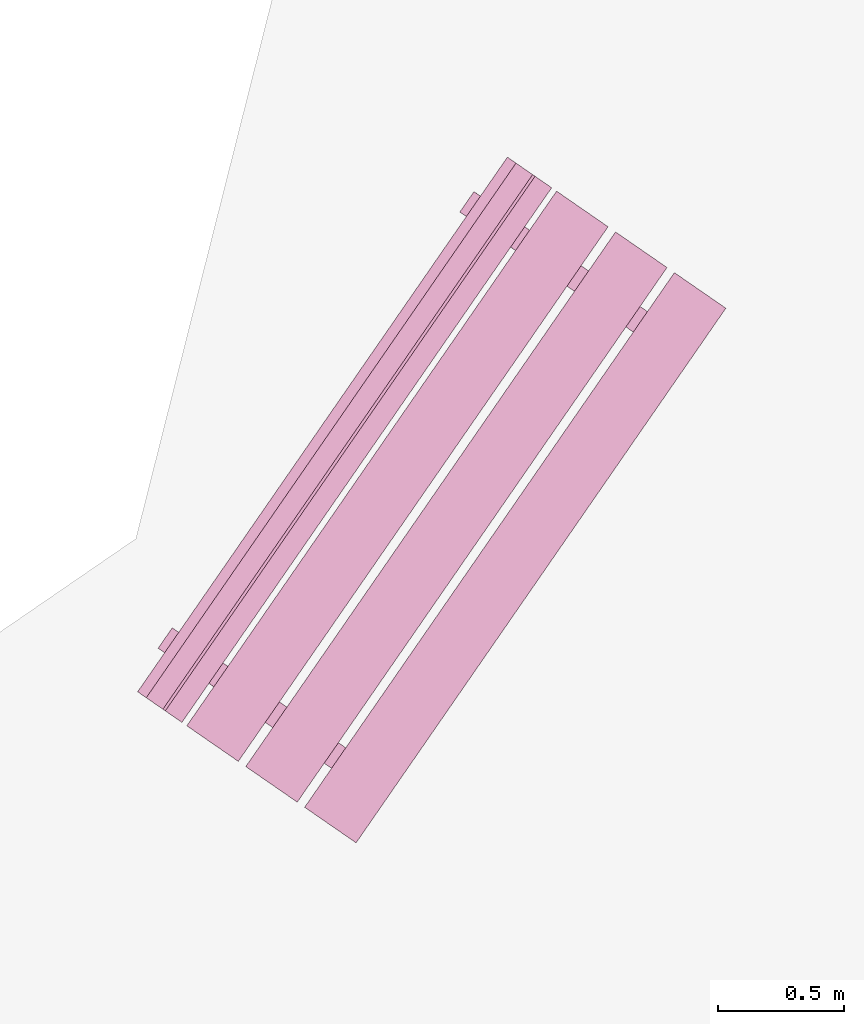
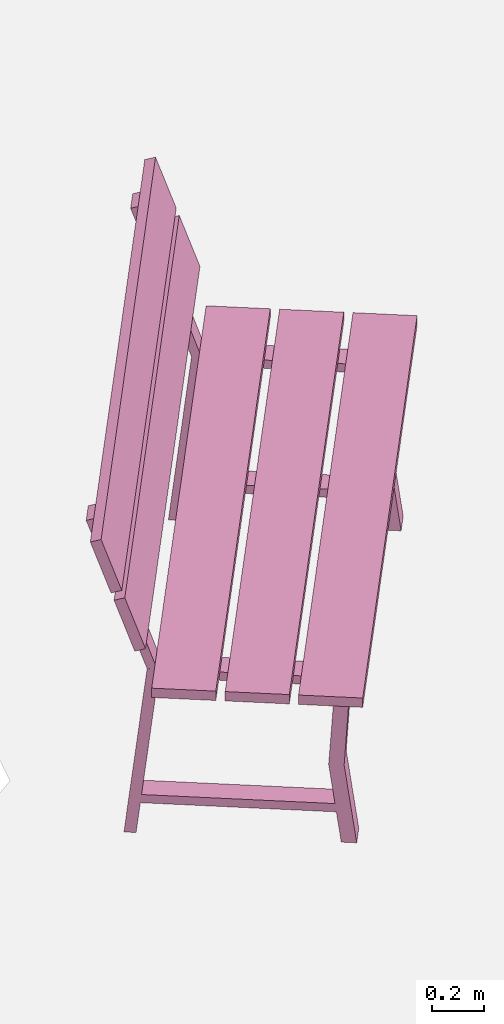
# One storey, part 14 of 200: 1 furnishing.
"""IFC4 building model written with IfcOpenShell, lengths in metres."""

from ifc_helpers import new_model, si_unit, origin_with_axes, place, context, subcontext, project, spatial, triangles, material, element, save


model = new_model("IFC4")

# Units and contexts
model_context = context("Model", 3, precision=1e-05, world=origin_with_axes())
body_context = subcontext(model_context, "Body", "Model", "MODEL_VIEW")
ifc_project = project(units=[si_unit("VOLUMEUNIT", "CUBIC_METRE"), si_unit("LENGTHUNIT", "METRE"), si_unit("AREAUNIT", "SQUARE_METRE")], contexts=[model_context])

# Site, building, storey
site_placement = place(None, origin_with_axes())
site = spatial("IfcSite", under=ifc_project, at=site_placement)
building_placement = place(site_placement, origin_with_axes())
building = spatial("IfcBuilding", under=site, at=building_placement, Name="Building")
storey_placement = place(building_placement, origin_with_axes())
storey = spatial("IfcBuildingStorey", under=building, at=storey_placement, Name="Ground")

# Furnishing
ifc_material = material(Name="bench")
furnishing_placement = place(storey_placement, origin_with_axes())
element("IfcFurnishingElement", 1, at=furnishing_placement, inside=storey, material=ifc_material, Name="cw_instances_bench_31", context=body_context, shape_type="Tessellation", body=[
    triangles([(430.49522774524286, -703.2783294763524, 0.815520754558246), (430.2910358391865, -703.1371042373619, 0.815520754558246), (428.8237559205569, -705.2585853935971, 0.815520754558246), (429.02794782661323, -705.3998106325876, 0.815520754558246), (429.2476401460873, -705.322571509684, 0.36316797911391596), (429.30358175396947, -705.2416877836379, 0.36316797911391596), (429.3437593569992, -705.2694758174514, 1.4462435886752271e-07), (429.28781774911704, -705.3503595434976, 1.4462435886752271e-07), (429.35287856693344, -705.2757829362165, 0.36316797911391596), (429.3369824254762, -705.384363306442, 1.6069373207502523e-07), (429.3929240333583, -705.3034795803958, 1.6069373207502523e-07), (429.29693695905127, -705.3566666622627, 0.36316797911391596), (428.72602921428864, -704.8422351460613, 0.7742224172068448), (428.72602921428864, -704.8422351460613, 0.7742224172068448), (428.6521501820918, -704.7911381942776, 0.0), (428.59620857420964, -704.8720219203237, 0.0), (428.59620857420964, -704.8720219203237, 0.0), (428.6698133918, -704.9235153480034, 0.7742224172068448), (428.7610524324257, -704.8664582528785, 0.7346917591163886), (428.6349323706113, -704.8988044579231, 1.6069373207502518e-08), (428.69087397849347, -704.8179207318769, 1.6069373207502518e-08), (428.70511082454357, -704.9473419789247, 0.7353345501140619), (429.26746456205393, -705.3362826696257, 0.7353346465303011), (429.32367049601095, -705.255581759411, 0.7346918555326278), (429.3733637716546, -705.2899511174554, 0.7742225618312036), (429.317147949166, -705.3712313193976, 0.7742225618312036), (430.7287598191776, -703.4398472543601, 0.8155208509744852), (430.52456792633757, -703.2986220245103, 0.815520754558246), (429.05728800770794, -705.4201031807455, 0.815520754558246), (429.26147990054795, -705.5613284105953, 0.8155208509744852), (430.26129915576325, -703.1165374563158, 0.815520754558246), (430.0571072629232, -702.975312226466, 0.8155206581420068), (428.58982734429355, -705.0967933827012, 0.8155206581420068), (428.7940192371336, -705.238018612551, 0.815520754558246), (430.0375471201662, -702.9617838457928, 0.9999971268416286), (428.5043177929904, -705.0376524155004, 1.2349312667190762), (428.5702672015366, -705.0832650020279, 0.9999971268416286), (429.97159771162, -702.9161712592652, 1.2349312667190762), (429.9620819597082, -702.9095898801896, 1.2691590637898031), (428.42885265896496, -704.9854584681789, 1.5040931072510113), (428.4948020410786, -705.0310710364248, 1.2691590637898031), (429.8961325775946, -702.8639773119436, 1.5040931072510113), (428.4759807751702, -704.7890641955373, 1.4584561837579435), (428.5319224378971, -704.7081803901933, 1.4584561837579435), (428.72602921428864, -704.8422351460613, 0.7742224172068448), (428.6698133918, -704.9235153480034, 0.7742224172068448), (428.7016745723539, -704.9449653639741, 0.7739010297426947), (428.75721970434006, -704.8638074233215, 0.7739010297426947), (428.5632450777697, -704.7298440662286, 1.4724364581016047), (428.5076998909388, -704.811002086179, 1.4724364581016047), (428.5360369616241, -705.0595903427052, 0.9858560302109066), (428.47021970289904, -705.0140691549526, 1.2207902665045935), (430.00331688025375, -702.93810918647, 0.9858560302109066), (429.9374996215287, -702.8925879987174, 1.2207902665045935), (428.46057181438243, -705.0073963862429, 1.2550180635753205), (428.3946224190525, -704.9617838088561, 1.4899522998690073), (429.92785173301206, -702.8859152300076, 1.2550180635753205), (429.8619023376821, -702.840302652621, 1.4899522998690073), (430.4448096279412, -703.5916321951564, 0.36316797911391596), (430.5007512358234, -703.5107484691102, 0.36316797911391596), (430.54092883885306, -703.5385365029238, 1.4462435886752271e-07), (430.48498723097094, -703.61942022897, 1.4462435886752271e-07), (430.55004804878735, -703.5448436216889, 0.36316797911391596), (430.53415190733006, -703.6534239919143, 1.6069373207502523e-07), (430.59009351521223, -703.5725402658683, 1.6069373207502523e-07), (430.49410644090517, -703.625727347735, 0.36316797911391596), (429.9231986961425, -703.1112958315337, 0.7742224172068448), (429.9231986961425, -703.1112958315337, 0.7742224172068448), (429.8493196639457, -703.0601988797499, 0.0), (429.79337805606355, -703.1410826057961, 0.0), (429.79337805606355, -703.1410826057961, 0.0), (429.86707424500645, -703.1924439233036, 0.7742224172068448), (429.9582219142796, -703.135518938351, 0.7346917591163886), (429.8321018524652, -703.1678651433955, 1.6069373207502518e-08), (429.8880434603473, -703.0869814173493, 1.6069373207502518e-08), (429.9022803063974, -703.2164026643972, 0.7353345501140619), (430.46463404390784, -703.6053433550982, 0.7353346465303011), (430.52083997786485, -703.5246424448835, 0.7346918555326278), (430.57053325350853, -703.5590118029278, 0.7742225618312036), (430.5144088023725, -703.6401598946977, 0.7742225618312036), (429.6732416832214, -703.0579926915397, 1.4584561837579435), (429.7290919288918, -702.9772410624495, 1.4584561837579435), (429.9231986961425, -703.1112958315337, 0.7742224172068448), (429.86707424500645, -703.1924439233036, 0.7742224172068448), (429.89884405420776, -703.2140260494466, 0.7739010297426947), (429.9543891861939, -703.1328681087939, 0.7739010297426947), (429.76041456876436, -702.9989047384846, 1.4724364581016047), (429.70496079899, -703.0799305821814, 1.4724364581016047), (430.2910358391865, -703.1371042373619, 0.815520754558246), (428.8237559205569, -705.2585853935971, 0.7716513657017641), (428.8237559205569, -705.2585853935971, 0.815520754558246), (430.2910358391865, -703.1371042373619, 0.7716513657017641), (430.49522774524286, -703.2783294763524, 0.7716514139098837), (429.02794782661323, -705.3998106325876, 0.815520754558246), (429.02794782661323, -705.3998106325876, 0.7716514139098837), (430.49522774524286, -703.2783294763524, 0.815520754558246), (429.28781774911704, -705.3503595434976, 1.4462435886752271e-07), (429.29693695905127, -705.3566666622627, 0.36316797911391596), (429.2476401460873, -705.322571509684, 0.36316797911391596), (429.3369824254762, -705.384363306442, 1.6069373207502523e-07), (428.70511082454357, -704.9473419789247, 0.7353345501140619), (428.6698133918, -704.9235153480034, 0.7742224172068448), (428.59620857420964, -704.8720219203237, 0.0), (428.6349323706113, -704.8988044579231, 1.6069373207502518e-08), (429.35287856693344, -705.2757829362165, 0.36316797911391596), (429.30358175396947, -705.2416877836379, 0.36316797911391596), (429.32367049601095, -705.255581759411, 0.7346918555326278), (429.3733637716546, -705.2899511174554, 0.7742225618312036), (428.72602921428864, -704.8422351460613, 0.7742224172068448), (428.7610524324257, -704.8664582528785, 0.7346917591163886), (428.6521501820918, -704.7911381942776, 0.0), (428.69087397849347, -704.8179207318769, 1.6069373207502518e-08), (429.26746456205393, -705.3362826696257, 0.7353346465303011), (429.317147949166, -705.3712313193976, 0.7742225618312036), (429.3437593569992, -705.2694758174514, 1.4462435886752271e-07), (429.3929240333583, -705.3034795803958, 1.6069373207502523e-07), (428.4759807751702, -704.7890641955373, 1.4584561837579435), (428.5632450777697, -704.7298440662286, 1.4724364581016047), (428.5319224378971, -704.7081803901933, 1.4584561837579435), (428.5076998909388, -704.811002086179, 1.4724364581016047), (428.6994855092711, -704.8252444089607, 0.13996424063734697), (428.6994855092711, -704.8252444089607, 0.17949489872780322), (429.33624701042584, -705.2656477379531, 0.13996438526170585), (429.33664351275445, -705.2659219708412, 0.17949504335216207), (428.6446407598149, -704.9045422314227, 0.17949489872780322), (428.6448236030688, -704.904277865699, 0.1406070155656471), (429.281320791365, -705.3444983880007, 0.14060716019000596), (429.2817987632983, -705.3452197933034, 0.17949504335216207), (430.52456792633757, -703.2986220245103, 0.815520754558246), (429.05728800770794, -705.4201031807455, 0.7716514139098837), (429.05728800770794, -705.4201031807455, 0.815520754558246), (430.52456792633757, -703.2986220245103, 0.7716514139098837), (430.7287598191776, -703.4398472543601, 0.7716514621180032), (429.26147990054795, -705.5613284105953, 0.8155208509744852), (429.26147990054795, -705.5613284105953, 0.7716514621180032), (430.7287598191776, -703.4398472543601, 0.8155208509744852), (430.0571072629232, -702.975312226466, 0.8155206581420068), (428.58982734429355, -705.0967933827012, 0.7716513174936444), (428.58982734429355, -705.0967933827012, 0.8155206581420068), (430.0571072629232, -702.975312226466, 0.7716513174936444), (430.2612991689795, -703.1165374654565, 0.7716513657017641), (428.7940192371336, -705.238018612551, 0.815520754558246), (428.7940192503499, -705.2380186216917, 0.7716513657017641), (430.26129915576325, -703.1165374563158, 0.815520754558246), (428.47021970289904, -705.0140691549526, 1.2207902665045935), (429.97159771162, -702.9161712592652, 1.2349312667190762), (429.9374996215287, -702.8925879987174, 1.2207902665045935), (428.5043177929904, -705.0376524155004, 1.2349312667190762), (430.00331688025375, -702.93810918647, 0.9858560302109066), (428.5702672015366, -705.0832650020279, 0.9999971268416286), (428.5360369616241, -705.0595903427052, 0.9858560302109066), (430.0375471201662, -702.9617838457928, 0.9999971268416286), (428.3946224190525, -704.9617838088561, 1.4899522998690073), (429.8961325775946, -702.8639773119436, 1.5040931072510113), (429.8619023376821, -702.840302652621, 1.4899522998690073), (428.42885265896496, -704.9854584681789, 1.5040931072510113), (429.92785173301206, -702.8859152300076, 1.2550180635753205), (428.4948020410786, -705.0310710364248, 1.2691590637898031), (428.46057181438243, -705.0073963862429, 1.2550180635753205), (429.9620819597082, -702.9095898801896, 1.2691590637898031), (430.48498723097094, -703.61942022897, 1.4462435886752271e-07), (430.49410644090517, -703.625727347735, 0.36316797911391596), (430.4448096279412, -703.5916321951564, 0.36316797911391596), (430.53415190733006, -703.6534239919143, 1.6069373207502523e-07), (429.9022803063974, -703.2164026643972, 0.7353345501140619), (429.86707424500645, -703.1924439233036, 0.7742224172068448), (429.79337805606355, -703.1410826057961, 0.0), (429.8321018524652, -703.1678651433955, 1.6069373207502518e-08), (430.55004804878735, -703.5448436216889, 0.36316797911391596), (430.5007512358234, -703.5107484691102, 0.36316797911391596), (430.52083997786485, -703.5246424448835, 0.7346918555326278), (430.57053325350853, -703.5590118029278, 0.7742225618312036), (429.9231986961425, -703.1112958315337, 0.7742224172068448), (429.9582219142796, -703.135518938351, 0.7346917591163886), (429.8493196639457, -703.0601988797499, 0.0), (429.8880434603473, -703.0869814173493, 1.6069373207502518e-08), (430.46463404390784, -703.6053433550982, 0.7353346465303011), (430.5144088023725, -703.6401598946977, 0.7742225618312036), (430.54092883885306, -703.5385365029238, 1.4462435886752271e-07), (430.59009351521223, -703.5725402658683, 1.6069373207502523e-07), (429.6732416832214, -703.0579926915397, 1.4584561837579435), (429.76041456876436, -702.9989047384846, 1.4724364581016047), (429.7290919288918, -702.9772410624495, 1.4584561837579435), (429.70496079899, -703.0799305821814, 1.4724364581016047), (429.89674641732233, -703.094172904963, 0.13996424063734697), (429.89674641732233, -703.094172904963, 0.17949489872780322), (430.5335079184771, -703.5345762339555, 0.13996438526170585), (430.5339044208057, -703.5348504668435, 0.17949504335216207), (429.8418102416688, -703.1736029168952, 0.17949489872780322), (429.8420844562753, -703.1732064409991, 0.1406070155656471), (430.4785816445715, -703.613426963301, 0.14060716019000596), (430.47896824515215, -703.6142804787758, 0.17949504335216207), (430.49522774524286, -703.2783294763524, 0.815520754558246), (430.2910358391865, -703.1371042373619, 0.7716513657017641), (430.2910358391865, -703.1371042373619, 0.815520754558246), (430.49522774524286, -703.2783294763524, 0.7716514139098837), (428.8237559205569, -705.2585853935971, 0.815520754558246), (428.8237559205569, -705.2585853935971, 0.7716513657017641), (429.02794782661323, -705.3998106325876, 0.7716514139098837), (429.02794782661323, -705.3998106325876, 0.815520754558246), (430.7287598191776, -703.4398472543601, 0.8155208509744852), (430.52456792633757, -703.2986220245103, 0.7716514139098837), (430.52456792633757, -703.2986220245103, 0.815520754558246), (430.7287598191776, -703.4398472543601, 0.7716514621180032), (429.05728800770794, -705.4201031807455, 0.815520754558246), (429.05728800770794, -705.4201031807455, 0.7716514139098837), (429.26147990054795, -705.5613284105953, 0.7716514621180032), (429.26147990054795, -705.5613284105953, 0.8155208509744852), (430.26129915576325, -703.1165374563158, 0.815520754558246), (430.0571072629232, -702.975312226466, 0.7716513174936444), (430.0571072629232, -702.975312226466, 0.8155206581420068), (430.2612991689795, -703.1165374654565, 0.7716513657017641), (428.58982734429355, -705.0967933827012, 0.8155206581420068), (428.58982734429355, -705.0967933827012, 0.7716513174936444), (428.7940192503499, -705.2380186216917, 0.7716513657017641), (428.7940192371336, -705.238018612551, 0.815520754558246), (430.00331688025375, -702.93810918647, 0.9858560302109066), (429.9374996215287, -702.8925879987174, 1.2207902665045935), (429.97159771162, -702.9161712592652, 1.2349312667190762), (430.0375471201662, -702.9617838457928, 0.9999971268416286), (428.5043177929904, -705.0376524155004, 1.2349312667190762), (428.5360369616241, -705.0595903427052, 0.9858560302109066), (428.5702672015366, -705.0832650020279, 0.9999971268416286), (428.47021970289904, -705.0140691549526, 1.2207902665045935), (429.92785173301206, -702.8859152300076, 1.2550180635753205), (429.8619023376821, -702.840302652621, 1.4899522998690073), (429.8961325775946, -702.8639773119436, 1.5040931072510113), (429.9620819597082, -702.9095898801896, 1.2691590637898031), (428.42885265896496, -704.9854584681789, 1.5040931072510113), (428.46057181438243, -705.0073963862429, 1.2550180635753205), (428.4948020410786, -705.0310710364248, 1.2691590637898031), (428.3946224190525, -704.9617838088561, 1.4899522998690073), (428.75721970434006, -704.8638074233215, 0.7739010297426947), (428.5632450777697, -704.7298440662286, 1.4724364581016047), (428.5319224378971, -704.7081803901933, 1.4584561837579435), (428.6698133918, -704.9235153480034, 0.7742224172068448), (428.7016745723539, -704.9449653639741, 0.7739010297426947), (428.5076998909388, -704.811002086179, 1.4724364581016047), (428.4759807751702, -704.7890641955373, 1.4584561837579435), (429.9543891861939, -703.1328681087939, 0.7739010297426947), (429.76041456876436, -702.9989047384846, 1.4724364581016047), (429.7290919288918, -702.9772410624495, 1.4584561837579435), (429.86707424500645, -703.1924439233036, 0.7742224172068448), (429.89884405420776, -703.2140260494466, 0.7739010297426947), (429.70496079899, -703.0799305821814, 1.4724364581016047), (429.6732416832214, -703.0579926915397, 1.4584561837579435), (428.72602921428864, -704.8422351460613, 0.7742224172068448), (428.6698133918, -704.9235153480034, 0.7742224172068448), (429.3733637716546, -705.2899511174554, 0.7742225618312036), (429.317147949166, -705.3712313193976, 0.7742225618312036), (428.6994855092711, -704.8252444089607, 0.17949489872780322), (428.6446407598149, -704.9045422314227, 0.17949489872780322), (429.33664351275445, -705.2659219708412, 0.17949504335216207), (429.2817987632983, -705.3452197933034, 0.17949504335216207), (429.9231986961425, -703.1112958315337, 0.7742224172068448), (429.86707424500645, -703.1924439233036, 0.7742224172068448), (430.57053325350853, -703.5590118029278, 0.7742225618312036), (430.5144088023725, -703.6401598946977, 0.7742225618312036), (429.89674641732233, -703.094172904963, 0.17949489872780322), (429.8418102416688, -703.1736029168952, 0.17949489872780322), (430.5339044208057, -703.5348504668435, 0.17949504335216207), (430.47896824515215, -703.6142804787758, 0.17949504335216207)], [[1, 2, 3], [3, 4, 1], [5, 6, 7], [7, 8, 5], [9, 10, 11], [10, 9, 12], [14, 15, 16], [17, 18, 13], [19, 20, 21], [20, 19, 22], [23, 24, 5], [24, 6, 5], [12, 9, 25], [25, 26, 12], [27, 28, 29], [29, 30, 27], [31, 32, 33], [33, 34, 31], [35, 36, 37], [35, 38, 36], [39, 40, 41], [39, 42, 40], [43, 44, 45], [45, 46, 43], [47, 48, 49], [49, 50, 47], [51, 52, 53], [54, 53, 52], [55, 56, 57], [58, 57, 56], [59, 60, 61], [61, 62, 59], [63, 64, 65], [64, 63, 66], [68, 69, 71], [70, 72, 67], [73, 74, 75], [74, 73, 76], [77, 78, 59], [78, 60, 59], [66, 63, 79], [79, 80, 66], [81, 82, 83], [83, 84, 81], [85, 86, 87], [87, 88, 85], [89, 90, 91], [89, 92, 90], [93, 94, 95], [93, 96, 94], [97, 98, 99], [97, 100, 98], [101, 102, 103], [103, 104, 101], [105, 106, 107], [107, 108, 105], [109, 110, 111], [110, 112, 111], [108, 107, 109], [107, 110, 109], [113, 99, 98], [98, 114, 113], [115, 106, 105], [105, 116, 115], [117, 118, 119], [117, 120, 118], [102, 101, 113], [113, 114, 102], [121, 122, 123], [122, 124, 123], [125, 126, 127], [127, 128, 125], [129, 130, 131], [129, 132, 130], [133, 134, 135], [133, 136, 134], [137, 138, 139], [137, 140, 138], [141, 142, 143], [141, 144, 142], [145, 146, 147], [145, 148, 146], [149, 150, 151], [149, 152, 150], [153, 154, 155], [153, 156, 154], [157, 158, 159], [157, 160, 158], [161, 162, 163], [161, 164, 162], [165, 166, 167], [167, 168, 165], [169, 170, 171], [171, 172, 169], [173, 174, 175], [174, 176, 175], [172, 171, 173], [171, 174, 173], [177, 163, 162], [162, 178, 177], [179, 170, 169], [169, 180, 179], [181, 182, 183], [181, 184, 182], [166, 165, 177], [177, 178, 166], [185, 186, 187], [186, 188, 187], [189, 190, 191], [191, 192, 189], [193, 194, 195], [194, 193, 196], [197, 198, 199], [199, 200, 197], [201, 202, 203], [202, 201, 204], [205, 206, 207], [207, 208, 205], [209, 210, 211], [210, 209, 212], [213, 214, 215], [215, 216, 213], [217, 218, 219], [219, 220, 217], [221, 222, 223], [222, 221, 224], [225, 226, 227], [227, 228, 225], [229, 230, 231], [230, 229, 232], [233, 109, 234], [109, 235, 234], [236, 237, 238], [238, 239, 236], [240, 173, 241], [173, 242, 241], [243, 244, 245], [245, 246, 243], [247, 248, 249], [248, 250, 249], [251, 252, 253], [252, 254, 253], [255, 256, 257], [256, 258, 257], [259, 260, 261], [260, 262, 261]], closed=True),
])

save(model, "model.ifc")
